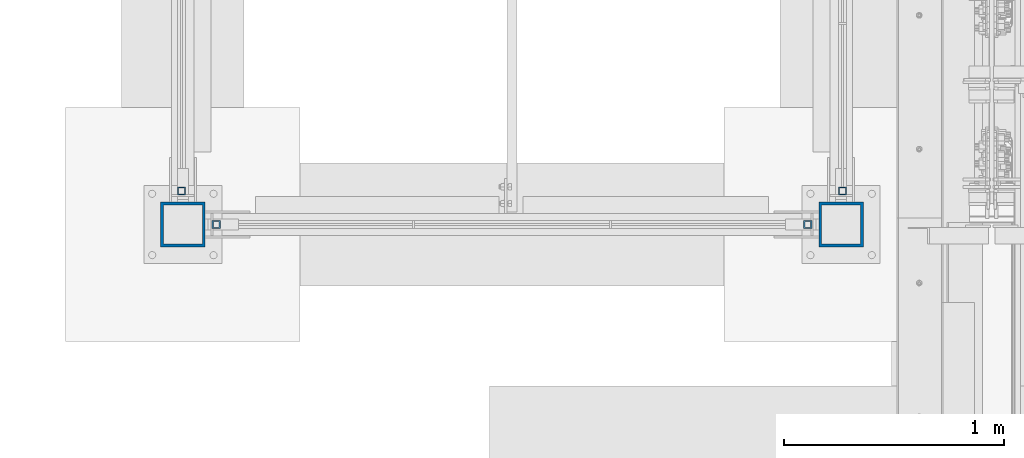
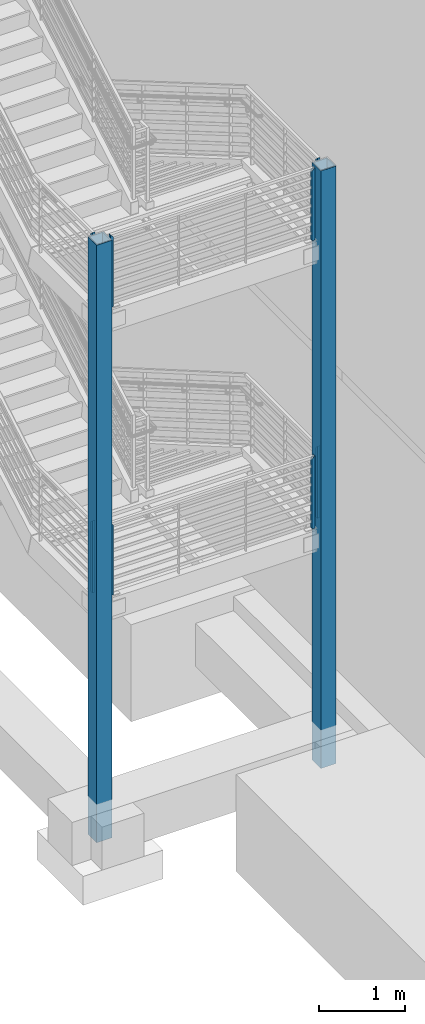
# One storey, part 358 of 1179: 10 columns, 8 elements without a shape of their own.
"""IFC2X3 building model written with IfcOpenShell, lengths in millimetres."""

from ifc_helpers import new_model, si_unit, frame, origin_with_axes, place, context, subcontext, project, spatial, faceted_brep, material, type_object, element, aggregate, save


model = new_model("IFC2X3")

# Units and contexts
model_context = context("Model", 3, precision=1e-05, world=origin_with_axes())
body_context = subcontext(model_context, "Body", "Model", "MODEL_VIEW")
ifc_project = project(units=[si_unit("LENGTHUNIT", "METRE", prefix="MILLI"), si_unit("AREAUNIT", "SQUARE_METRE"), si_unit("VOLUMEUNIT", "CUBIC_METRE"), si_unit("MASSUNIT", "GRAM", prefix="KILO"), si_unit("TIMEUNIT", "SECOND"), si_unit("PLANEANGLEUNIT", "RADIAN"), si_unit("SOLIDANGLEUNIT", "STERADIAN"), si_unit("THERMODYNAMICTEMPERATUREUNIT", "DEGREE_CELSIUS"), si_unit("LUMINOUSINTENSITYUNIT", "LUMEN")], contexts=[model_context])

# Site, building, storey
site_placement = place(None, origin_with_axes())
site = spatial("IfcSite", under=ifc_project, at=site_placement, CompositionType="ELEMENT")
building_placement = place(site_placement, origin_with_axes())
building = spatial("IfcBuilding", under=site, at=building_placement, Name="Undefined", CompositionType="ELEMENT")
storey_placement = place(building_placement, origin_with_axes())
storey = spatial("IfcBuildingStorey", under=building, at=storey_placement, Name="Undefined", CompositionType="ELEMENT", Elevation=0.0)

# Assembly, columns
assembly_1_placement = place(storey_placement, origin_with_axes())
assembly_1 = element("IfcElementAssembly", 1, at=assembly_1_placement, inside=storey, Name="GUARDRAIL", AssemblyPlace="NOTDEFINED", PredefinedType="RIGID_FRAME")
ifc_material = material()
column_type_1 = type_object("IfcColumnType", Name="HSS1-1/2X1-1/2X1/4", PredefinedType="NOTDEFINED")
column_1_placement = place(assembly_1_placement, frame((-406.4, 30073.6, 6254.75), z_axis=(-1.0, 0.0, 0.0), x_axis=(0.0, 0.0, 1.0)))
column_1 = element("IfcColumn", 2, at=column_1_placement, type_object=column_type_1, material=ifc_material, Name="POST", ObjectType="HSS1-1/2X1-1/2X1/4", context=body_context, shape_type="Brep", body=[
    faceted_brep([(2.27373675443232e-13, 12.6999993300487, -12.6999993299996), (-6.82121026329696e-13, -12.6999993300415, -12.6999993299996), (1016.05291868232, -12.6999993299978, -12.69999933), (1016.05291868232, 12.6999993299978, -12.69999933), (-6.82121026329696e-13, -12.6999993300415, 12.6999993299996), (990.652920022321, -12.6999993299978, 12.69999933), (2.27373675443232e-13, 12.6999993300487, 12.6999993299996), (990.652920022321, 12.6999993299978, 12.69999933), (0.0, 19.0499992350015, -19.0499992349996), (0.0, 19.0499992350015, 19.0499992349996), (984.302920117321, 19.0499992350015, 19.049999235), (1022.40291858732, 19.0499992350015, -19.049999235), (0.0, -19.0499992350015, 19.0499992349996), (984.302920117321, -19.0499992350015, 19.049999235), (0.0, -19.0499992350015, -19.0499992349996), (1022.40291858732, -19.0499992350015, -19.049999235)], [[[0, 1, 2, 3]], [[1, 4, 5, 2]], [[4, 6, 7, 5]], [[6, 0, 3, 7]], [[8, 9, 10, 11]], [[9, 12, 13, 10]], [[12, 14, 15, 13]], [[14, 8, 11, 15]], [[13, 15, 11, 10], [5, 7, 3, 2]], [[14, 12, 9, 8], [6, 4, 1, 0]]]),
])
column_2_placement = place(assembly_1_placement, frame((-3098.8, 30073.6, 6254.75000031022), z_axis=(-1.0, 0.0, 0.0), x_axis=(0.0, 0.0, 1.0)))
column_2 = element("IfcColumn", 3, at=column_2_placement, type_object=column_type_1, material=ifc_material, Name="POST", ObjectType="HSS1-1/2X1-1/2X1/4", context=body_context, shape_type="Brep", body=[
    faceted_brep([(2.27373675443232e-13, 12.6999993300487, -12.6999993299996), (-6.82121026329696e-13, -12.6999993300415, -12.6999993299996), (990.652919712098, -12.6999993299978, -12.6999993300001), (990.652919712098, 12.6999993299978, -12.6999993300001), (-6.82121026329696e-13, -12.6999993300415, 12.6999993299996), (1016.0529183721, -12.6999993299978, 12.6999993300001), (2.27373675443232e-13, 12.6999993300487, 12.6999993299996), (1016.0529183721, 12.6999993299978, 12.6999993300001), (0.0, 19.0499992350015, -19.0499992349996), (0.0, 19.0499992350015, 19.0499992349996), (1022.4029182771, 19.0499992350015, 19.0499992350001), (984.302919807098, 19.0499992350015, -19.0499992350001), (0.0, -19.0499992350015, 19.0499992349996), (1022.4029182771, -19.0499992350015, 19.0499992350001), (0.0, -19.0499992350015, -19.0499992349996), (984.302919807098, -19.0499992350015, -19.0499992350001)], [[[0, 1, 2, 3]], [[1, 4, 5, 2]], [[4, 6, 7, 5]], [[6, 0, 3, 7]], [[8, 9, 10, 11]], [[9, 12, 13, 10]], [[12, 14, 15, 13]], [[14, 8, 11, 15]], [[13, 15, 11, 10], [5, 7, 3, 2]], [[14, 12, 9, 8], [6, 4, 1, 0]]]),
])
aggregate(assembly_1, [column_1, column_2])

# Assembly, column
assembly_2_placement = place(storey_placement, origin_with_axes())
assembly_2 = element("IfcElementAssembly", 4, at=assembly_2_placement, inside=storey, Name="GUARDRAIL", AssemblyPlace="NOTDEFINED", PredefinedType="RIGID_FRAME")
column_3_placement = place(assembly_2_placement, frame((-3257.54999923555, 30226.0, 6254.75), z_axis=(-1.0, 0.0, 0.0), x_axis=(0.0, 0.0, 1.0)))
column_3 = element("IfcColumn", 5, at=column_3_placement, type_object=column_type_1, material=ifc_material, Name="POST", ObjectType="HSS1-1/2X1-1/2X1/4", context=body_context, shape_type="Brep", body=[
    faceted_brep([(2.27373675443232e-13, 12.6999993300487, -12.6999993299996), (-6.82121026329696e-13, -12.6999993300415, -12.6999993299996), (1016.0534104503, -12.6999993300014, -12.6999993300001), (990.652426349769, 12.6999993300014, -12.6999993300001), (-6.82121026329696e-13, -12.6999993300415, 12.6999993299996), (1016.0534104503, -12.6999993300014, 12.6999993300001), (2.27373675443232e-13, 12.6999993300487, 12.6999993299996), (990.652426349769, 12.6999993300014, 12.6999993300001), (0.0, 19.0499992350015, -19.0499992349996), (0.0, 19.0499992350015, 19.0499992349996), (984.302180084628, 19.0499992350015, 19.0499992350001), (984.302180084628, 19.0499992350015, -19.0499992350001), (0.0, -19.0499992350015, 19.0499992349996), (1022.40365671544, -19.0499992350015, 19.0499992350001), (0.0, -19.0499992350015, -19.0499992349996), (1022.40365671544, -19.0499992350015, -19.0499992350001)], [[[0, 1, 2, 3]], [[1, 4, 5, 2]], [[4, 6, 7, 5]], [[6, 0, 3, 7]], [[8, 9, 10, 11]], [[9, 12, 13, 10]], [[12, 14, 15, 13]], [[14, 8, 11, 15]], [[13, 15, 11, 10], [5, 7, 3, 2]], [[14, 12, 9, 8], [6, 4, 1, 0]]]),
])
aggregate(assembly_2, [column_3])

assembly_3_placement = place(storey_placement, origin_with_axes())
assembly_3 = element("IfcElementAssembly", 6, at=assembly_3_placement, inside=storey, Name="GUARDRAIL", AssemblyPlace="NOTDEFINED", PredefinedType="RIGID_FRAME")
column_4_placement = place(assembly_3_placement, frame((-3257.54999923555, 30226.0, 2181.225), z_axis=(-1.0, 0.0, 0.0), x_axis=(0.0, 0.0, 1.0)))
column_4 = element("IfcColumn", 7, at=column_4_placement, type_object=column_type_1, material=ifc_material, Name="POST", ObjectType="HSS1-1/2X1-1/2X1/4", context=body_context, shape_type="Brep", body=[
    faceted_brep([(2.27373675443232e-13, 12.6999993300487, -12.6999993299996), (-6.82121026329696e-13, -12.6999993300415, -12.6999993299996), (1016.00049171775, -12.6999993300014, -12.6999993300001), (990.599507617223, 12.6999993300014, -12.6999993300001), (-6.82121026329696e-13, -12.6999993300415, 12.6999993299996), (1016.00049171775, -12.6999993300014, 12.6999993300001), (2.27373675443232e-13, 12.6999993300487, 12.6999993299996), (990.599507617223, 12.6999993300014, 12.6999993300001), (0.0, 19.0499992350015, -19.0499992349996), (0.0, 19.0499992350015, 19.0499992349996), (984.249261352082, 19.0499992350015, 19.0499992350001), (984.249261352082, 19.0499992350015, -19.0499992350001), (0.0, -19.0499992350015, 19.0499992349996), (1022.35073798289, -19.0499992350015, 19.0499992350001), (0.0, -19.0499992350015, -19.0499992349996), (1022.35073798289, -19.0499992350015, -19.0499992350001)], [[[0, 1, 2, 3]], [[1, 4, 5, 2]], [[4, 6, 7, 5]], [[6, 0, 3, 7]], [[8, 9, 10, 11]], [[9, 12, 13, 10]], [[12, 14, 15, 13]], [[14, 8, 11, 15]], [[13, 15, 11, 10], [5, 7, 3, 2]], [[14, 12, 9, 8], [6, 4, 1, 0]]]),
])
aggregate(assembly_3, [column_4])

# Assembly, columns
assembly_4_placement = place(storey_placement, origin_with_axes())
assembly_4 = element("IfcElementAssembly", 8, at=assembly_4_placement, inside=storey, Name="GUARDRAIL", AssemblyPlace="NOTDEFINED", PredefinedType="RIGID_FRAME")
column_5_placement = place(assembly_4_placement, frame((-406.4, 30073.6, 2181.22499968978), z_axis=(-1.0, 0.0, 0.0), x_axis=(0.0, 0.0, 1.0)))
column_5 = element("IfcColumn", 9, at=column_5_placement, type_object=column_type_1, material=ifc_material, Name="POST", ObjectType="HSS1-1/2X1-1/2X1/4", context=body_context, shape_type="Brep", body=[
    faceted_brep([(2.27373675443232e-13, 12.6999993300487, -12.6999993299996), (-6.82121026329696e-13, -12.6999993300415, -12.6999993299996), (1016.05291868232, -12.6999993299978, -12.69999933), (1016.05291868232, 12.6999993299978, -12.69999933), (-6.82121026329696e-13, -12.6999993300415, 12.6999993299996), (990.652920022321, -12.6999993299978, 12.69999933), (2.27373675443232e-13, 12.6999993300487, 12.6999993299996), (990.652920022321, 12.6999993299978, 12.69999933), (0.0, 19.0499992350015, -19.0499992349996), (0.0, 19.0499992350015, 19.0499992349996), (984.302920117321, 19.0499992350015, 19.049999235), (1022.40291858732, 19.0499992350015, -19.049999235), (0.0, -19.0499992350015, 19.0499992349996), (984.302920117321, -19.0499992350015, 19.049999235), (0.0, -19.0499992350015, -19.0499992349996), (1022.40291858732, -19.0499992350015, -19.049999235)], [[[0, 1, 2, 3]], [[1, 4, 5, 2]], [[4, 6, 7, 5]], [[6, 0, 3, 7]], [[8, 9, 10, 11]], [[9, 12, 13, 10]], [[12, 14, 15, 13]], [[14, 8, 11, 15]], [[13, 15, 11, 10], [5, 7, 3, 2]], [[14, 12, 9, 8], [6, 4, 1, 0]]]),
])
column_6_placement = place(assembly_4_placement, frame((-3098.8, 30073.6, 2181.225), z_axis=(-1.0, 0.0, 0.0), x_axis=(0.0, 0.0, 1.0)))
column_6 = element("IfcColumn", 10, at=column_6_placement, type_object=column_type_1, material=ifc_material, Name="POST", ObjectType="HSS1-1/2X1-1/2X1/4", context=body_context, shape_type="Brep", body=[
    faceted_brep([(2.27373675443232e-13, 12.6999993300487, -12.6999993299996), (-6.82121026329696e-13, -12.6999993300415, -12.6999993299996), (990.652919712098, -12.6999993299978, -12.6999993300001), (990.652919712098, 12.6999993299978, -12.6999993300001), (-6.82121026329696e-13, -12.6999993300415, 12.6999993299996), (1016.0529183721, -12.6999993299978, 12.6999993300001), (2.27373675443232e-13, 12.6999993300487, 12.6999993299996), (1016.0529183721, 12.6999993299978, 12.6999993300001), (0.0, 19.0499992350015, -19.0499992349996), (0.0, 19.0499992350015, 19.0499992349996), (1022.4029182771, 19.0499992350015, 19.0499992350001), (984.302919807098, 19.0499992350015, -19.0499992350001), (0.0, -19.0499992350015, 19.0499992349996), (1022.4029182771, -19.0499992350015, 19.0499992350001), (0.0, -19.0499992350015, -19.0499992349996), (984.302919807098, -19.0499992350015, -19.0499992350001)], [[[0, 1, 2, 3]], [[1, 4, 5, 2]], [[4, 6, 7, 5]], [[6, 0, 3, 7]], [[8, 9, 10, 11]], [[9, 12, 13, 10]], [[12, 14, 15, 13]], [[14, 8, 11, 15]], [[13, 15, 11, 10], [5, 7, 3, 2]], [[14, 12, 9, 8], [6, 4, 1, 0]]]),
])
aggregate(assembly_4, [column_5, column_6])

# Assembly, column
assembly_5_placement = place(storey_placement, origin_with_axes())
assembly_5 = element("IfcElementAssembly", 11, at=assembly_5_placement, inside=storey, Name="GUARDRAIL", AssemblyPlace="NOTDEFINED", PredefinedType="RIGID_FRAME")
column_7_placement = place(assembly_5_placement, frame((-247.650000744516, 30225.9983091721, 6254.69708113904), z_axis=(-1.0, 0.0, 0.0), x_axis=(0.0, 1.69599999891578e-06, 0.999999999998562)))
column_7 = element("IfcColumn", 12, at=column_7_placement, type_object=column_type_1, material=ifc_material, Name="POST", ObjectType="HSS1-1/2X1-1/2X1/4", context=body_context, shape_type="Brep", body=[
    faceted_brep([(2.27373675443232e-13, 12.6999993300487, -12.6999993299996), (-6.82121026329696e-13, -12.6999993300415, -12.6999993299996), (1016.05291868232, -12.6999993299978, -12.69999933), (990.652919712098, 12.6999993299978, -12.6999993300001), (-6.82121026329696e-13, -12.6999993300415, 12.6999993299996), (1016.0529183721, -12.6999993299978, 12.6999993300001), (2.27373675443232e-13, 12.6999993300487, 12.6999993299996), (990.652920022321, 12.6999993299978, 12.69999933), (0.0, 19.0499992350015, -19.0499992349996), (0.0, 19.0499992350015, 19.0499992349996), (984.302920117321, 19.0499992350015, 19.049999235), (984.302919807098, 19.0499992350015, -19.0499992350001), (0.0, -19.0499992350015, 19.0499992349996), (1022.4029182771, -19.0499992350015, 19.0499992350001), (0.0, -19.0499992350015, -19.0499992349996), (1022.40291858732, -19.0499992350015, -19.049999235)], [[[0, 1, 2, 3]], [[1, 4, 5, 2]], [[4, 6, 7, 5]], [[6, 0, 3, 7]], [[8, 9, 10, 11]], [[9, 12, 13, 10]], [[12, 14, 15, 13]], [[14, 8, 11, 15]], [[13, 15, 11, 10], [5, 7, 3, 2]], [[14, 12, 9, 8], [6, 4, 1, 0]]]),
])
aggregate(assembly_5, [column_7])

assembly_6_placement = place(storey_placement, origin_with_axes())
assembly_6 = element("IfcElementAssembly", 13, at=assembly_6_placement, inside=storey, Name="GUARDRAIL", AssemblyPlace="NOTDEFINED", PredefinedType="RIGID_FRAME")
column_8_placement = place(assembly_6_placement, frame((-247.650000744516, 30225.9983091725, 2181.225), z_axis=(-1.0, 0.0, 0.0), x_axis=(0.0, 1.69599999891578e-06, 0.999999999998562)))
column_8 = element("IfcColumn", 14, at=column_8_placement, type_object=column_type_1, material=ifc_material, Name="POST", ObjectType="HSS1-1/2X1-1/2X1/4", context=body_context, shape_type="Brep", body=[
    faceted_brep([(2.27373675443232e-13, 12.6999993300487, -12.6999993299996), (-6.82121026329696e-13, -12.6999993300415, -12.6999993299996), (1016.05291868232, -12.6999993299978, -12.69999933), (990.652919712098, 12.6999993299978, -12.6999993300001), (-6.82121026329696e-13, -12.6999993300415, 12.6999993299996), (1016.0529183721, -12.6999993299978, 12.6999993300001), (2.27373675443232e-13, 12.6999993300487, 12.6999993299996), (990.652920022321, 12.6999993299978, 12.69999933), (0.0, 19.0499992350015, -19.0499992349996), (0.0, 19.0499992350015, 19.0499992349996), (984.302920117321, 19.0499992350015, 19.049999235), (984.302919807098, 19.0499992350015, -19.0499992350001), (0.0, -19.0499992350015, 19.0499992349996), (1022.4029182771, -19.0499992350015, 19.0499992350001), (0.0, -19.0499992350015, -19.0499992349996), (1022.40291858732, -19.0499992350015, -19.049999235)], [[[0, 1, 2, 3]], [[1, 4, 5, 2]], [[4, 6, 7, 5]], [[6, 0, 3, 7]], [[8, 9, 10, 11]], [[9, 12, 13, 10]], [[12, 14, 15, 13]], [[14, 8, 11, 15]], [[13, 15, 11, 10], [5, 7, 3, 2]], [[14, 12, 9, 8], [6, 4, 1, 0]]]),
])
aggregate(assembly_6, [column_8])

assembly_7_placement = place(storey_placement, origin_with_axes())
assembly_7 = element("IfcElementAssembly", 15, at=assembly_7_placement, inside=storey, Name="COLUMN", AssemblyPlace="NOTDEFINED", PredefinedType="RIGID_FRAME")
column_type_2 = type_object("IfcColumnType", Name="HSS8X8X1/2", PredefinedType="NOTDEFINED")
column_9_placement = place(assembly_7_placement, frame((-254.0, 30073.6, -1244.6), z_axis=(0.0, 1.0, 0.0), x_axis=(0.0, 0.0, 1.0)))
column_9 = element("IfcColumn", 16, at=column_9_placement, type_object=column_type_2, material=ifc_material, Name="COLUMN", ObjectType="HSS8X8X1/2", context=body_context, shape_type="Brep", body=[
    faceted_brep([(63.5, 88.9, -88.9000000000015), (63.5, -88.9, -88.9000000000015), (8512.175, -88.9, -88.9000000000015), (8512.175, 88.9, -88.9000000000015), (63.5, -88.9, 88.9000000000015), (8512.175, -88.9, 88.9000000000015), (63.5, 88.9, 88.9000000000015), (8512.175, 88.9, 88.9000000000015), (63.5, 101.6, -101.599999999999), (63.5, 101.6, 101.599999999999), (8512.175, 101.6, 101.599999999999), (8512.175, 101.6, -101.599999999999), (63.5, -101.6, 101.599999999999), (8512.175, -101.6, 101.599999999999), (63.5, -101.6, -101.599999999999), (8512.175, -101.6, -101.599999999999)], [[[0, 1, 2, 3]], [[1, 4, 5, 2]], [[4, 6, 7, 5]], [[6, 0, 3, 7]], [[8, 9, 10, 11]], [[9, 12, 13, 10]], [[12, 14, 15, 13]], [[14, 8, 11, 15]], [[13, 15, 11, 10], [5, 7, 3, 2]], [[14, 12, 9, 8], [6, 4, 1, 0]]]),
])
aggregate(assembly_7, [column_9])

assembly_8_placement = place(storey_placement, origin_with_axes())
assembly_8 = element("IfcElementAssembly", 17, at=assembly_8_placement, inside=storey, Name="COLUMN", AssemblyPlace="NOTDEFINED", PredefinedType="RIGID_FRAME")
column_10_placement = place(assembly_8_placement, frame((-3251.2, 30073.6, -1244.6), z_axis=(0.0, 1.0, 0.0), x_axis=(0.0, 0.0, 1.0)))
column_10 = element("IfcColumn", 18, at=column_10_placement, type_object=column_type_2, material=ifc_material, Name="COLUMN", ObjectType="HSS8X8X1/2", context=body_context, shape_type="Brep", body=[
    faceted_brep([(63.5, 88.9, -88.9000000000015), (63.5, -88.9, -88.9000000000015), (8512.175, -88.9, -88.9000000000015), (8512.175, 88.9, -88.9000000000015), (63.5, -88.9, 88.9000000000015), (8512.175, -88.9, 88.9000000000015), (63.5, 88.9, 88.9000000000015), (8512.175, 88.9, 88.9000000000015), (63.5, 101.6, -101.599999999999), (63.5, 101.6, 101.599999999999), (8512.175, 101.6, 101.599999999999), (8512.175, 101.6, -101.599999999999), (63.5, -101.6, 101.599999999999), (8512.175, -101.6, 101.599999999999), (63.5, -101.6, -101.599999999999), (8512.175, -101.6, -101.599999999999)], [[[0, 1, 2, 3]], [[1, 4, 5, 2]], [[4, 6, 7, 5]], [[6, 0, 3, 7]], [[8, 9, 10, 11]], [[9, 12, 13, 10]], [[12, 14, 15, 13]], [[14, 8, 11, 15]], [[13, 15, 11, 10], [5, 7, 3, 2]], [[14, 12, 9, 8], [6, 4, 1, 0]]]),
])
aggregate(assembly_8, [column_10])

save(model, "model.ifc")
